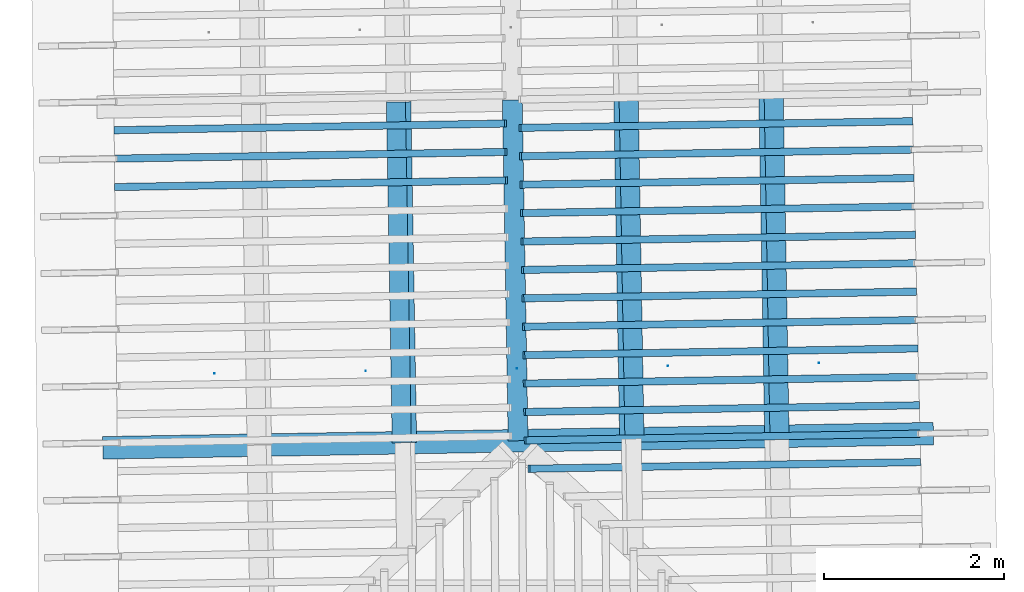
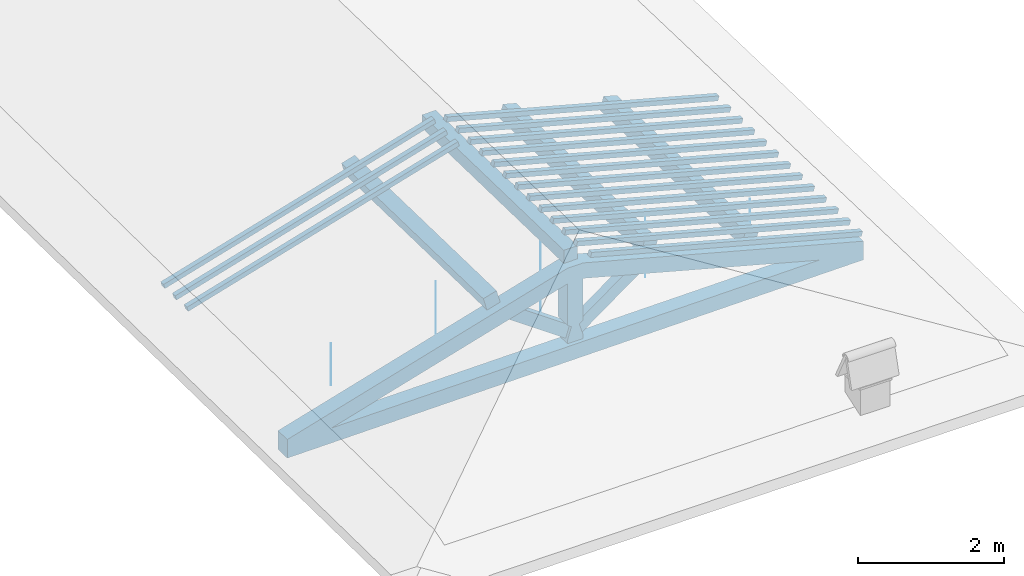
# One storey, part 3 of 19: 18 beams, 4 members, 2 elements without a shape of their own.
"""IFC4 building model written with IfcOpenShell, lengths in metres."""

from ifc_helpers import new_model, entity, si_unit, converted_unit, derived_unit, direction, frame, origin, place, context, subcontext, project, spatial, arc, indexed_curve, outline, extrude, source, transform, mapped, material, type_object, type_shapes, element, aggregate, save


model = new_model("IFC4")

# Units and contexts
model_context = context("Model", 3, precision=1e-05, world=origin(), true_north=direction((6.123233995736766e-17, 1.0)))
body_context = subcontext(model_context, "Body", "Model", "MODEL_VIEW")
ifc_project = project(units=[si_unit("LENGTHUNIT", "METRE"), si_unit("AREAUNIT", "SQUARE_METRE"), si_unit("VOLUMEUNIT", "CUBIC_METRE"), converted_unit("PLANEANGLEUNIT", "DEGREE", entity("IfcPlaneAngleMeasure", 0.017453292519943278), si_unit("PLANEANGLEUNIT", "RADIAN"), dimensions=[0, 0, 0, 0, 0, 0, 0]), derived_unit("THERMALTRANSMITTANCEUNIT", [(si_unit("MASSUNIT", "GRAM", prefix="KILO"), 1), (si_unit("THERMODYNAMICTEMPERATUREUNIT", "KELVIN"), -1), (si_unit("TIMEUNIT", "SECOND"), -3)])], contexts=[model_context])

# Site, building, storey
site_placement = place(None, origin())
site = spatial("IfcSite", under=ifc_project, at=site_placement, CompositionType="ELEMENT")
building_placement = place(site_placement, origin())
building = spatial("IfcBuilding", under=site, at=building_placement, CompositionType="ELEMENT")
storey_placement = place(building_placement, frame((0.0, 0.0, 3.28)))
storey = spatial("IfcBuildingStorey", under=building, at=storey_placement, Name="Livello Copertura", CompositionType="ELEMENT", Elevation=3.28)

# Beam
ifc_material_1 = material(Name="Telaio", Category="Legno")
beam_type_1 = type_object("IfcBeamType", Name="con e 18x18 2", PredefinedType="BEAM", material=ifc_material_1)
shared_shape_1 = source(origin(), body_context, "Body", "SweptSolid", [
    extrude(outline(indexed_curve([(-0.16541753369488893, -2.7162453774766275), (0.08463069471711139, -2.716245377476629), (0.16842467663126645, 1.5495047236372541), (-0.01356084740826559, 1.9493040088108127), (-0.07407699024522271, 1.933682022505188), (-0.16541753369488893, -2.7162453774766275)], self_intersect=False)), frame((-2.713680684761416, -0.12500000000000352, 0.5116016056385222), z_axis=(0.0, 1.0, 0.0), x_axis=(0.24995178089011919, 0.0, -0.9682582853917946)), (0.0, 0.0, 1.0), 0.24999999999999992),
    extrude(outline(indexed_curve([(-2.718970219470431, -0.11203953208496607), (1.9318542149690596, -0.11203953208496614), (1.9486617037575076, -0.05184187166013539), (1.5525136616356172, 0.137960467915034), (-2.7140593608917554, 0.137960467915034), (-2.718970219470431, -0.11203953208496607)], self_intersect=False)), frame((2.7136806847614197, -0.12500000000000352, 0.5116016056385372), z_axis=(0.0, 1.0, 0.0), x_axis=(0.9631625667976574, 0.0, -0.2689198206152686)), (0.0, 0.0, 1.0), 0.24999999999999992),
    extrude(outline(indexed_curve([(-0.5601835339455478, -0.12499999999999746), (-0.49768353394554415, -0.12499999999999749), (-0.2968792817361453, -0.062499999999998515), (-0.2526268150406443, -0.12499999999999746), (0.4434537562213674, -0.12499999999999747), (0.4609040697695109, -0.06249999999999742), (0.7030153386769692, -0.12499999999999746), (0.7030153386769719, 0.1249999999999892), (0.46090406976954656, 0.06249999999999748), (0.4434537562214021, 0.12499999999999911), (-0.2526268150406462, 0.12499999999999915), (-0.29687928173614625, 0.06250000000000018), (-0.4976835339455446, 0.12499999999999908), (-0.5601835339455477, 0.12499999999999911), (-0.5601835339455478, -0.12499999999999746)], self_intersect=False)), frame((0.0, -0.12500000000000397, 0.647683533945542), z_axis=(0.0, 1.0, 0.0), x_axis=(0.0, 0.0, 1.0)), (0.0, 0.0, 1.0), 0.24999999999999992),
    extrude(outline(indexed_curve([(-4.548711713227807, -0.7192326477239056), (-4.505299668811077, -0.9654345859769559), (4.563794928678348, 0.6336914821578127), (4.520382884261614, 0.8798934204108596), (4.107604035615938, 0.7296542061691604), (3.82531022235883, 0.7573333565645375), (-3.8536390513249863, -0.5966725838775957), (-4.109441637550861, -0.7192326477239057), (-4.548711713227807, -0.7192326477239056)], self_intersect=False)), frame((0.0, -0.12500000000000175, -0.0440696120362346), z_axis=(0.0, -1.0, 0.0), x_axis=(0.984807753012208, 0.0, -0.17364817766693108)), (0.0, 0.0, -1.0), 0.24999999999999986),
    extrude(outline(indexed_curve([(0.20359543107977635, -0.4090841915047363), (0.4613119776404389, -0.4090841915047362), (-0.27535475240621304, 0.4973840166014553), (-0.3895526563140025, 0.3207843664080172), (0.20359543107977635, -0.4090841915047363)], self_intersect=False)), frame((0.5239678106288662, -0.07500000000000369, 0.5550133154913391), z_axis=(0.0, 1.0, 0.0), x_axis=(0.9631625667976574, 0.0, -0.2689198206152682)), (0.0, 0.0, 1.0), 0.14999999999999994),
    extrude(outline(indexed_curve([(-0.4613119776404252, -0.4090841915047199), (-0.20359543107976297, -0.4090841915047199), (0.38955265631398844, 0.3207843664080003), (0.2753547524061997, 0.4973840166014395), (-0.4613119776404252, -0.4090841915047199)], self_intersect=False)), frame((-0.5239678106288467, -0.07500000000000369, 0.5550133154913305), z_axis=(0.0, 1.0, 0.0), x_axis=(0.9631625667976591, 0.0, 0.2689198206152626)), (0.0, 0.0, 1.0), 0.15),
])
type_shapes(beam_type_1, [shared_shape_1])
beam_1_placement = place(storey_placement, frame((-0.10915093127416141, 0.948347842470844, -0.33185813424974964), z_axis=(0.0, 0.0, 1.0), x_axis=(0.9998540424951864, 0.017084897015615302, 0.0)))
element("IfcBeam", 1, at=beam_1_placement, inside=storey, type_object=beam_type_1, material=ifc_material_1, Name="con e 18x18 2", ObjectType="con e 18x18 2", PredefinedType="BEAM", context=body_context, shape_type="MappedRepresentation", body=[
    mapped(shared_shape_1, transform((0.0, 0.0, 0.0), scale=1.0)),
])

# Members
ifc_material_2 = material(Name="Legno - Legno da costruzione", Category="Legno")
member_type_1 = type_object("IfcMemberType", Name="Legno:220x220", PredefinedType="PURLIN", material=ifc_material_2)
shared_shape_2 = source(origin(), body_context, "Body", "SweptSolid", [
    extrude(outline(indexed_curve([(-1.8889999897376843, -0.11000000000000167), (1.8889999897376841, -0.11000000000000167), (1.8889999897376843, 0.11000000000000167), (-1.8889999897376843, 0.11000000000000167), (-1.8889999897376843, -0.11000000000000167)], self_intersect=False)), frame((1.0262315609033124e-08, 0.0, -0.11000000000000543), z_axis=(0.0, 0.0, 1.0), x_axis=(-1.0, 0.0, 0.0)), (0.0, 0.0, 1.0), 0.21999999999999986),
])
type_shapes(member_type_1, [shared_shape_2])
member_1_placement = place(storey_placement, frame((-0.14155051099361587, 2.837069973977643, 1.1288407383727659), z_axis=(0.0, 0.0, 1.0), x_axis=(0.017084897015610563, -0.9998540424951864, 0.0)))
element("IfcMember", 2, at=member_1_placement, inside=storey, type_object=member_type_1, material=ifc_material_2, Name="Legno:220x220", ObjectType="Legno:220x220", PredefinedType="PURLIN", context=body_context, shape_type="MappedRepresentation", body=[
    mapped(shared_shape_2, transform((0.0, 0.0, 0.0), scale=1.0)),
])
member_type_2 = type_object("IfcMemberType", Name="Legno:220x220", PredefinedType="PURLIN", material=ifc_material_2)
shared_shape_3 = source(origin(), body_context, "Body", "SweptSolid", [
    extrude(outline(indexed_curve([(-0.11000000000000179, -0.10999999999999992), (0.1100000000000016, -0.11000000000000047), (0.11000000000000192, 0.10999999999999995), (-0.11000000000000132, 0.11), (-0.11000000000000179, -0.10999999999999992)], self_intersect=False)), frame((1.0867037662542156, 4.747207884589853, 4.096142666378187), z_axis=(0.01708489701561108, -0.9998540424951864, 0.0), x_axis=(-0.9630219859926791, -0.016455533263029863, 0.2689198206152636)), (0.0, 0.0, 1.0), 3.777999979475369),
])
type_shapes(member_type_2, [shared_shape_3])
member_2_placement = place(storey_placement, frame((0.0, 0.0, -3.28)))
element("IfcMember", 3, at=member_2_placement, inside=storey, type_object=member_type_2, material=ifc_material_2, Name="Legno:220x220", ObjectType="Legno:220x220", PredefinedType="PURLIN", context=body_context, shape_type="MappedRepresentation", body=[
    mapped(shared_shape_3, transform((0.0, 0.0, 0.0), scale=1.0)),
])
member_type_3 = type_object("IfcMemberType", Name="Legno:220x220", PredefinedType="PURLIN", material=ifc_material_2)
shared_shape_4 = source(origin(), body_context, "Body", "SweptSolid", [
    extrude(outline(indexed_curve([(-0.11000000000000161, -0.10999999999999995), (0.11000000000000143, -0.11000000000000047), (0.11000000000000161, 0.10999999999999995), (-0.11000000000000129, 0.10999999999999997), (-0.11000000000000161, -0.10999999999999995)], self_intersect=False)), frame((2.694765700683629, 4.774590186442459, 3.647098620102822), z_axis=(0.01708489701561113, -0.9998540424951865, 0.0), x_axis=(-0.963021985992679, -0.016455533263029905, 0.26891982061526426)), (0.0, 0.0, 1.0), 3.7779999794753683),
])
type_shapes(member_type_3, [shared_shape_4])
member_3_placement = place(storey_placement, frame((0.0, 0.0, -3.28)))
element("IfcMember", 4, at=member_3_placement, inside=storey, type_object=member_type_3, material=ifc_material_2, Name="Legno:220x220", ObjectType="Legno:220x220", PredefinedType="PURLIN", context=body_context, shape_type="MappedRepresentation", body=[
    mapped(shared_shape_4, transform((0.0, 0.0, 0.0), scale=1.0)),
])
member_type_4 = type_object("IfcMemberType", Name="Legno:220x220", PredefinedType="PURLIN", material=ifc_material_2)
shared_shape_5 = source(origin(), body_context, "Body", "SweptSolid", [
    extrude(outline(indexed_curve([(-0.11000000000000118, -0.11000000000000004), (0.11000000000000207, -0.10999999999999945), (0.11000000000000146, 0.10999999999999995), (-0.11000000000000193, 0.10999999999999997), (-0.11000000000000118, -0.11000000000000004)], self_intersect=False)), frame((-1.4340455079257437, 4.704385852621383, 4.096002252490915), z_axis=(0.017084897015611743, -0.9998540424951864, 0.0), x_axis=(-0.9630219859926791, -0.016455533263029863, -0.2689198206152636)), (0.0, 0.0, 1.0), 3.777999979475369),
])
type_shapes(member_type_4, [shared_shape_5])
member_4_placement = place(storey_placement, frame((0.0, 0.0, -3.28)))
element("IfcMember", 5, at=member_4_placement, inside=storey, type_object=member_type_4, material=ifc_material_2, Name="Legno:220x220", ObjectType="Legno:220x220", PredefinedType="PURLIN", context=body_context, shape_type="MappedRepresentation", body=[
    mapped(shared_shape_5, transform((0.0, 0.0, 0.0), scale=1.0)),
])

# Beam
ifc_material_3 = material(Name="Metallo - Acciaio - 345 MPa", Category="Metallo")
beam_type_2 = type_object("IfcBeamType", Name="Porta", PredefinedType="BEAM", material=ifc_material_3)
shared_shape_6 = source(origin(), body_context, "Body", "SweptSolid", [
    extrude(outline(indexed_curve([(-0.0025, 0.0), (-9.341026746681546e-18, -0.002499999999999973), (0.0025, 0.0), (1.5308084989342274e-19, 0.002499999999999973)], segments=[arc(1, 2, 3), arc(3, 4, 1)], self_intersect=False)), frame((3.3500000000000014, 0.0, 0.01799999999999821), z_axis=(0.0, 0.0, 1.0), x_axis=(0.0, -1.0, 0.0)), (0.0, 0.0, 1.0), 0.7000000000000034),
    extrude(outline(indexed_curve([(-0.0025, 0.0), (-9.341026746681546e-18, -0.002499999999999973), (0.0025, 0.0), (1.5308084989342274e-19, 0.002499999999999973)], segments=[arc(1, 2, 3), arc(3, 4, 1)], self_intersect=False)), frame((-3.350000000000001, 0.0, 0.01799999999999821), z_axis=(0.0, 0.0, 1.0), x_axis=(0.0, -1.0, 0.0)), (0.0, 0.0, 1.0), 0.7000000000000034),
    extrude(outline(indexed_curve([(-0.0025, 0.0), (-9.341026746681546e-18, -0.002499999999999973), (0.0025, 0.0), (1.5308084989342274e-19, 0.002499999999999973)], segments=[arc(1, 2, 3), arc(3, 4, 1)], self_intersect=False)), frame((1.6750000000000014, 0.0, 0.01799999999999821), z_axis=(0.0, 0.0, 1.0), x_axis=(0.0, -1.0, 0.0)), (0.0, 0.0, 1.0), 1.1350000000000036),
    extrude(outline(indexed_curve([(-0.0025, 0.0), (-9.341026746681546e-18, -0.002499999999999973), (0.0025, 0.0), (1.5308084989342274e-19, 0.002499999999999973)], segments=[arc(1, 2, 3), arc(3, 4, 1)], self_intersect=False)), frame((-1.6749999999999987, 0.0, 0.01799999999999821), z_axis=(0.0, 0.0, 1.0), x_axis=(0.0, -1.0, 0.0)), (0.0, 0.0, 1.0), 1.1350000000000036),
    extrude(outline(indexed_curve([(-0.0025, 4.038861436081489e-18), (-1.8222810943682823e-17, -0.0025000000000000044), (0.0025, -4.0388614360814286e-18), (3.483749923768857e-18, 0.0024999999999999957)], segments=[arc(1, 2, 3), arc(3, 4, 1)], self_intersect=False)), frame((0.0, 0.0, 0.017999999999998344), z_axis=(0.0, 0.0, 1.0), x_axis=(0.0, -1.0, 0.0)), (0.0, 0.0, 1.0), 1.350000000000003),
])
type_shapes(beam_type_2, [shared_shape_6])
beam_2_placement = place(storey_placement, frame((-0.12290406560098735, 1.750907887558534, -0.3492000000000056), z_axis=(0.0, 0.0, 1.0), x_axis=(0.9998547874088545, 0.017041246890830943, 0.0)))
element("IfcBeam", 6, at=beam_2_placement, inside=storey, type_object=beam_type_2, material=ifc_material_3, Name="Porta", ObjectType="Porta", PredefinedType="BEAM", context=body_context, shape_type="MappedRepresentation", body=[
    mapped(shared_shape_6, transform((0.0, 0.0, 0.0), scale=1.0)),
])

# Assembly, beams
assembly_1_placement = place(storey_placement, origin())
assembly_1 = element("IfcElementAssembly", 7, at=assembly_1_placement, inside=storey, Name="Sistema di travi strutturali:Sistema di travi strutturali", ObjectType="Sistema di travi strutturali:Sistema di travi strutturali", AssemblyPlace="NOTDEFINED", PredefinedType="BEAM_GRID")
beam_type_3 = type_object("IfcBeamType", Name="Legno:80x80", PredefinedType="JOIST", material=ifc_material_2)
shared_shape_7 = source(origin(), body_context, "Body", "SweptSolid", [
    extrude(outline(indexed_curve([(-2.247, -0.04000000000000169), (2.247, -0.04000000000000169), (2.247, 0.04000000000000169), (-2.247, 0.04000000000000169), (-2.247, -0.04000000000000169)], self_intersect=False)), frame((0.0, 0.0, -0.040000000000005476), z_axis=(0.0, 0.0, 1.0), x_axis=(-1.0, 0.0, 0.0)), (0.0, 0.0, 1.0), 0.07999999999999997),
])
type_shapes(beam_type_3, [shared_shape_7])
beam_3_placement = place(assembly_1_placement, frame((-2.412523717773911, 4.427895248678309, 0.6971087573780927), z_axis=(-0.26888056974925345, -0.004594467440668276, 0.9631625667976583), x_axis=(0.9630219859926786, 0.01645553326302695, 0.26891982061526537)))
beam_3 = element("IfcBeam", 8, at=beam_3_placement, type_object=beam_type_3, material=ifc_material_2, Name="Legno:80x80", ObjectType="Legno:80x80", PredefinedType="JOIST", context=body_context, shape_type="MappedRepresentation", body=[
    mapped(shared_shape_7, transform((0.0, 0.0, 0.0), scale=1.0)),
])
beam_type_4 = type_object("IfcBeamType", Name="Legno:80x80", PredefinedType="JOIST", material=ifc_material_2)
shared_shape_8 = source(origin(), body_context, "Body", "SweptSolid", [
    extrude(outline(indexed_curve([(-2.2485, -0.04000000000000169), (2.2485, -0.04000000000000169), (2.2485, 0.04000000000000169), (-2.2485, 0.04000000000000169), (-2.2485, -0.04000000000000169)], self_intersect=False)), frame((0.0, 0.0, -0.040000000000005476), z_axis=(0.0, 0.0, 1.0), x_axis=(-1.0, 0.0, 0.0)), (0.0, 0.0, 1.0), 0.07999999999999997),
])
type_shapes(beam_type_4, [shared_shape_8])
beam_4_placement = place(assembly_1_placement, frame((-2.4082892547392474, 4.1129216212784385, 0.6967883844181665), z_axis=(-0.26888056974925356, -0.0045944674406682776, 0.9631625667976583), x_axis=(0.9630219859926786, 0.01645553326302696, 0.2689198206152655)))
beam_4 = element("IfcBeam", 9, at=beam_4_placement, type_object=beam_type_4, material=ifc_material_2, Name="Legno:80x80", ObjectType="Legno:80x80", PredefinedType="JOIST", context=body_context, shape_type="MappedRepresentation", body=[
    mapped(shared_shape_8, transform((0.0, 0.0, 0.0), scale=1.0)),
])
beam_type_5 = type_object("IfcBeamType", Name="Legno:80x80", PredefinedType="JOIST", material=ifc_material_2)
shared_shape_9 = source(origin(), body_context, "Body", "SweptSolid", [
    extrude(outline(indexed_curve([(-2.2495, -0.04000000000000169), (2.2495, -0.04000000000000169), (2.2495, 0.04000000000000169), (-2.2495, 0.04000000000000169), (-2.2495, -0.04000000000000169)], self_intersect=False)), frame((0.0, 0.0, -0.040000000000005476), z_axis=(0.0, 0.0, 1.0), x_axis=(-1.0, 0.0, 0.0)), (0.0, 0.0, 1.0), 0.07999999999999997),
])
type_shapes(beam_type_5, [shared_shape_9])
beam_5_placement = place(assembly_1_placement, frame((-2.404054791704582, 3.797947993878563, 0.6964680114582396), z_axis=(-0.2688805697492535, -0.004594467440668276, 0.9631625667976583), x_axis=(0.9630219859926787, 0.016455533263026956, 0.2689198206152654)))
beam_5 = element("IfcBeam", 10, at=beam_5_placement, type_object=beam_type_5, material=ifc_material_2, Name="Legno:80x80", ObjectType="Legno:80x80", PredefinedType="JOIST", context=body_context, shape_type="MappedRepresentation", body=[
    mapped(shared_shape_9, transform((0.0, 0.0, 0.0), scale=1.0)),
])
aggregate(assembly_1, [beam_3, beam_4, beam_5])

assembly_2_placement = place(storey_placement, origin())
assembly_2 = element("IfcElementAssembly", 11, at=assembly_2_placement, inside=storey, Name="Sistema di travi strutturali:Sistema di travi strutturali", ObjectType="Sistema di travi strutturali:Sistema di travi strutturali", AssemblyPlace="NOTDEFINED", PredefinedType="BEAM_GRID")
beam_type_6 = type_object("IfcBeamType", Name="Legno:80x80", PredefinedType="JOIST", material=ifc_material_2)
shared_shape_10 = source(origin(), body_context, "Body", "SweptSolid", [
    extrude(outline(indexed_curve([(-2.2555, -0.04000000000000169), (2.2555, -0.04000000000000169), (2.2555, 0.04000000000000169), (-2.2555, 0.04000000000000169), (-2.2555, -0.04000000000000169)], self_intersect=False)), frame((0.0, 0.0, -0.040000000000005476), z_axis=(0.0, 0.0, 1.0), x_axis=(-1.0, 0.0, 0.0)), (0.0, 0.0, 1.0), 0.07999999999999997),
])
type_shapes(beam_type_6, [shared_shape_10])
beam_6_placement = place(assembly_2_placement, frame((2.082597457267619, 4.453794945756606, 0.6950774866976147), z_axis=(0.26888056974925345, 0.004594467440668277, 0.9631625667976583), x_axis=(-0.9630219859926786, -0.016455533263027795, 0.26891982061526537)))
beam_6 = element("IfcBeam", 12, at=beam_6_placement, type_object=beam_type_6, material=ifc_material_2, Name="Legno:80x80", ObjectType="Legno:80x80", PredefinedType="JOIST", context=body_context, shape_type="MappedRepresentation", body=[
    mapped(shared_shape_10, transform((0.0, 0.0, 0.0), scale=1.0)),
])
beam_type_7 = type_object("IfcBeamType", Name="Legno:80x80", PredefinedType="JOIST", material=ifc_material_2)
shared_shape_11 = source(origin(), body_context, "Body", "SweptSolid", [
    extrude(outline(indexed_curve([(-2.2565, -0.04000000000000169), (2.2565, -0.04000000000000169), (2.2565, 0.04000000000000169), (-2.2565, 0.04000000000000169), (-2.2565, -0.04000000000000169)], self_intersect=False)), frame((0.0, 0.0, -0.040000000000005476), z_axis=(0.0, 0.0, 1.0), x_axis=(-1.0, 0.0, 0.0)), (0.0, 0.0, 1.0), 0.07999999999999997),
])
type_shapes(beam_type_7, [shared_shape_11])
beam_7_placement = place(assembly_2_placement, frame((2.088990595047944, 4.138858204476255, 0.6947950588556767), z_axis=(0.26888056974925356, 0.004594467440668277, 0.9631625667976582), x_axis=(-0.9630219859926786, -0.016455533263027806, 0.2689198206152655)))
beam_7 = element("IfcBeam", 13, at=beam_7_placement, type_object=beam_type_7, material=ifc_material_2, Name="Legno:80x80", ObjectType="Legno:80x80", PredefinedType="JOIST", context=body_context, shape_type="MappedRepresentation", body=[
    mapped(shared_shape_11, transform((0.0, 0.0, 0.0), scale=1.0)),
])
beam_type_8 = type_object("IfcBeamType", Name="Legno:80x80", PredefinedType="JOIST", material=ifc_material_2)
shared_shape_12 = source(origin(), body_context, "Body", "SweptSolid", [
    extrude(outline(indexed_curve([(-2.2615, -0.04000000000000169), (2.2615, -0.04000000000000169), (2.2615, 0.04000000000000169), (-2.2615, 0.04000000000000169), (-2.2615, -0.04000000000000169)], self_intersect=False)), frame((0.0, 0.0, -0.040000000000005476), z_axis=(0.0, 0.0, 1.0), x_axis=(-1.0, 0.0, 0.0)), (0.0, 0.0, 1.0), 0.07999999999999997),
])
type_shapes(beam_type_8, [shared_shape_12])
beam_8_placement = place(assembly_2_placement, frame((2.1209562839495626, 2.564174498074516, 0.6933829196459858), z_axis=(0.26888056974925345, 0.004594467440668276, 0.9631625667976583), x_axis=(-0.9630219859926786, -0.016455533263027823, 0.26891982061526537)))
beam_8 = element("IfcBeam", 14, at=beam_8_placement, type_object=beam_type_8, material=ifc_material_2, Name="Legno:80x80", ObjectType="Legno:80x80", PredefinedType="JOIST", context=body_context, shape_type="MappedRepresentation", body=[
    mapped(shared_shape_12, transform((0.0, 0.0, 0.0), scale=1.0)),
])
beam_type_9 = type_object("IfcBeamType", Name="Legno:80x80", PredefinedType="JOIST", material=ifc_material_2)
shared_shape_13 = source(origin(), body_context, "Body", "SweptSolid", [
    extrude(outline(indexed_curve([(-2.249, -0.04000000000000169), (2.249, -0.04000000000000169), (2.249, 0.04000000000000169), (-2.249, 0.04000000000000169), (-2.249, -0.04000000000000169)], self_intersect=False)), frame((0.0, 0.0, -0.040000000000005476), z_axis=(0.0, 0.0, 1.0), x_axis=(-1.0, 0.0, 0.0)), (0.0, 0.0, 1.0), 0.07999999999999997),
])
type_shapes(beam_type_9, [shared_shape_13])
beam_9_placement = place(assembly_2_placement, frame((2.177684516118423, 0.6748679356073123, 0.6865587737267891), z_axis=(0.26888056974925334, 0.004594467440668274, 0.9631625667976583), x_axis=(-0.9630219859926787, -0.016455533263027886, 0.26891982061526526)))
beam_9 = element("IfcBeam", 15, at=beam_9_placement, type_object=beam_type_9, material=ifc_material_2, Name="Legno:80x80", ObjectType="Legno:80x80", PredefinedType="JOIST", context=body_context, shape_type="MappedRepresentation", body=[
    mapped(shared_shape_13, transform((0.0, 0.0, 0.0), scale=1.0)),
])
beam_type_10 = type_object("IfcBeamType", Name="Legno:80x80", PredefinedType="JOIST", material=ifc_material_2)
shared_shape_14 = source(origin(), body_context, "Body", "SweptSolid", [
    extrude(outline(indexed_curve([(-2.267, -0.04000000000000169), (2.267, -0.04000000000000169), (2.267, 0.04000000000000169), (-2.267, 0.04000000000000169), (-2.267, -0.04000000000000169)], self_intersect=False)), frame((0.0, 0.0, -0.040000000000005476), z_axis=(0.0, 0.0, 1.0), x_axis=(-1.0, 0.0, 0.0)), (0.0, 0.0, 1.0), 0.07999999999999997),
])
type_shapes(beam_type_10, [shared_shape_14])
beam_10_placement = place(assembly_2_placement, frame((2.15292197285118, 0.9894907916727746, 0.6919707804362961), z_axis=(0.2688805697492535, 0.004594467440668278, 0.9631625667976583), x_axis=(-0.9630219859926786, -0.016455533263027868, 0.2689198206152654)))
beam_10 = element("IfcBeam", 16, at=beam_10_placement, type_object=beam_type_10, material=ifc_material_2, Name="Legno:80x80", ObjectType="Legno:80x80", PredefinedType="JOIST", context=body_context, shape_type="MappedRepresentation", body=[
    mapped(shared_shape_14, transform((0.0, 0.0, 0.0), scale=1.0)),
])
beam_type_11 = type_object("IfcBeamType", Name="Legno:80x80", PredefinedType="JOIST", material=ifc_material_2)
shared_shape_15 = source(origin(), body_context, "Body", "SweptSolid", [
    extrude(outline(indexed_curve([(-2.266, -0.04000000000000169), (2.266, -0.04000000000000169), (2.266, 0.04000000000000169), (-2.266, 0.04000000000000169), (-2.266, -0.04000000000000169)], self_intersect=False)), frame((0.0, 0.0, -0.040000000000005476), z_axis=(0.0, 0.0, 1.0), x_axis=(-1.0, 0.0, 0.0)), (0.0, 0.0, 1.0), 0.07999999999999997),
])
type_shapes(beam_type_11, [shared_shape_15])
beam_11_placement = place(assembly_2_placement, frame((2.1465288350708565, 1.304427532953123, 0.6922532082782331), z_axis=(0.2688805697492534, 0.004594467440668276, 0.9631625667976583), x_axis=(-0.9630219859926786, -0.016455533263027892, 0.2689198206152653)))
beam_11 = element("IfcBeam", 17, at=beam_11_placement, type_object=beam_type_11, material=ifc_material_2, Name="Legno:80x80", ObjectType="Legno:80x80", PredefinedType="JOIST", context=body_context, shape_type="MappedRepresentation", body=[
    mapped(shared_shape_15, transform((0.0, 0.0, 0.0), scale=1.0)),
])
beam_type_12 = type_object("IfcBeamType", Name="Legno:80x80", PredefinedType="JOIST", material=ifc_material_2)
shared_shape_16 = source(origin(), body_context, "Body", "SweptSolid", [
    extrude(outline(indexed_curve([(-2.265, -0.04000000000000169), (2.265, -0.04000000000000169), (2.265, 0.04000000000000169), (-2.265, 0.04000000000000169), (-2.265, -0.04000000000000169)], self_intersect=False)), frame((0.0, 0.0, -0.040000000000005476), z_axis=(0.0, 0.0, 1.0), x_axis=(-1.0, 0.0, 0.0)), (0.0, 0.0, 1.0), 0.07999999999999997),
])
type_shapes(beam_type_12, [shared_shape_16])
beam_12_placement = place(assembly_2_placement, frame((2.1401356972905323, 1.6193642742334715, 0.6925356361201712), z_axis=(0.26888056974925345, 0.004594467440668275, 0.9631625667976583), x_axis=(-0.9630219859926786, -0.016455533263027886, 0.26891982061526537)))
beam_12 = element("IfcBeam", 18, at=beam_12_placement, type_object=beam_type_12, material=ifc_material_2, Name="Legno:80x80", ObjectType="Legno:80x80", PredefinedType="JOIST", context=body_context, shape_type="MappedRepresentation", body=[
    mapped(shared_shape_16, transform((0.0, 0.0, 0.0), scale=1.0)),
])
beam_type_13 = type_object("IfcBeamType", Name="Legno:80x80", PredefinedType="JOIST", material=ifc_material_2)
shared_shape_17 = source(origin(), body_context, "Body", "SweptSolid", [
    extrude(outline(indexed_curve([(-2.2635, -0.04000000000000169), (2.2635, -0.04000000000000169), (2.2635, 0.04000000000000169), (-2.2635, 0.04000000000000169), (-2.2635, -0.04000000000000169)], self_intersect=False)), frame((0.0, 0.0, -0.040000000000005476), z_axis=(0.0, 0.0, 1.0), x_axis=(-1.0, 0.0, 0.0)), (0.0, 0.0, 1.0), 0.07999999999999997),
])
type_shapes(beam_type_13, [shared_shape_17])
beam_13_placement = place(assembly_2_placement, frame((2.133742559510209, 1.9343010155138194, 0.69281806396211), z_axis=(0.2688805697492534, 0.004594467440668275, 0.9631625667976583), x_axis=(-0.9630219859926787, -0.016455533263027886, 0.2689198206152653)))
beam_13 = element("IfcBeam", 19, at=beam_13_placement, type_object=beam_type_13, material=ifc_material_2, Name="Legno:80x80", ObjectType="Legno:80x80", PredefinedType="JOIST", context=body_context, shape_type="MappedRepresentation", body=[
    mapped(shared_shape_17, transform((0.0, 0.0, 0.0), scale=1.0)),
])
beam_type_14 = type_object("IfcBeamType", Name="Legno:80x80", PredefinedType="JOIST", material=ifc_material_2)
shared_shape_18 = source(origin(), body_context, "Body", "SweptSolid", [
    extrude(outline(indexed_curve([(-2.2625, -0.04000000000000169), (2.2625, -0.04000000000000169), (2.2625, 0.04000000000000169), (-2.2625, 0.04000000000000169), (-2.2625, -0.04000000000000169)], self_intersect=False)), frame((0.0, 0.0, -0.040000000000005476), z_axis=(0.0, 0.0, 1.0), x_axis=(-1.0, 0.0, 0.0)), (0.0, 0.0, 1.0), 0.07999999999999997),
])
type_shapes(beam_type_14, [shared_shape_18])
beam_14_placement = place(assembly_2_placement, frame((2.1273494217298854, 2.2492377567941673, 0.693100491804048), z_axis=(0.2688805697492534, 0.004594467440668275, 0.9631625667976583), x_axis=(-0.9630219859926786, -0.01645553326302788, 0.2689198206152653)))
beam_14 = element("IfcBeam", 20, at=beam_14_placement, type_object=beam_type_14, material=ifc_material_2, Name="Legno:80x80", ObjectType="Legno:80x80", PredefinedType="JOIST", context=body_context, shape_type="MappedRepresentation", body=[
    mapped(shared_shape_18, transform((0.0, 0.0, 0.0), scale=1.0)),
])
beam_type_15 = type_object("IfcBeamType", Name="Legno:80x80", PredefinedType="JOIST", material=ifc_material_2)
shared_shape_19 = source(origin(), body_context, "Body", "SweptSolid", [
    extrude(outline(indexed_curve([(-2.2605, -0.04000000000000169), (2.2605, -0.04000000000000169), (2.2605, 0.04000000000000169), (-2.2605, 0.04000000000000169), (-2.2605, -0.04000000000000169)], self_intersect=False)), frame((0.0, 0.0, -0.040000000000005476), z_axis=(0.0, 0.0, 1.0), x_axis=(-1.0, 0.0, 0.0)), (0.0, 0.0, 1.0), 0.07999999999999997),
])
type_shapes(beam_type_15, [shared_shape_19])
beam_15_placement = place(assembly_2_placement, frame((2.114563146169238, 2.879111239354864, 0.6936653474879233), z_axis=(0.26888056974925345, 0.004594467440668276, 0.9631625667976583), x_axis=(-0.9630219859926786, -0.01645553326302782, 0.26891982061526537)))
beam_15 = element("IfcBeam", 21, at=beam_15_placement, type_object=beam_type_15, material=ifc_material_2, Name="Legno:80x80", ObjectType="Legno:80x80", PredefinedType="JOIST", context=body_context, shape_type="MappedRepresentation", body=[
    mapped(shared_shape_19, transform((0.0, 0.0, 0.0), scale=1.0)),
])
beam_type_16 = type_object("IfcBeamType", Name="Legno:80x80", PredefinedType="JOIST", material=ifc_material_2)
shared_shape_20 = source(origin(), body_context, "Body", "SweptSolid", [
    extrude(outline(indexed_curve([(-2.2595, -0.04000000000000169), (2.2595, -0.04000000000000169), (2.2595, 0.04000000000000169), (-2.2595, 0.04000000000000169), (-2.2595, -0.04000000000000169)], self_intersect=False)), frame((0.0, 0.0, -0.040000000000005476), z_axis=(0.0, 0.0, 1.0), x_axis=(-1.0, 0.0, 0.0)), (0.0, 0.0, 1.0), 0.07999999999999997),
])
type_shapes(beam_type_16, [shared_shape_20])
beam_16_placement = place(assembly_2_placement, frame((2.1081700083889143, 3.1940479806352116, 0.6939477753298616), z_axis=(0.2688805697492534, 0.004594467440668275, 0.9631625667976583), x_axis=(-0.9630219859926786, -0.016455533263027816, 0.2689198206152653)))
beam_16 = element("IfcBeam", 22, at=beam_16_placement, type_object=beam_type_16, material=ifc_material_2, Name="Legno:80x80", ObjectType="Legno:80x80", PredefinedType="JOIST", context=body_context, shape_type="MappedRepresentation", body=[
    mapped(shared_shape_20, transform((0.0, 0.0, 0.0), scale=1.0)),
])
beam_type_17 = type_object("IfcBeamType", Name="Legno:80x80", PredefinedType="JOIST", material=ifc_material_2)
shared_shape_21 = source(origin(), body_context, "Body", "SweptSolid", [
    extrude(outline(indexed_curve([(-2.2585, -0.04000000000000169), (2.2585, -0.04000000000000169), (2.2585, 0.04000000000000169), (-2.2585, 0.04000000000000169), (-2.2585, -0.04000000000000169)], self_intersect=False)), frame((0.0, 0.0, -0.040000000000005476), z_axis=(0.0, 0.0, 1.0), x_axis=(-1.0, 0.0, 0.0)), (0.0, 0.0, 1.0), 0.07999999999999997),
])
type_shapes(beam_type_17, [shared_shape_21])
beam_17_placement = place(assembly_2_placement, frame((2.1017768706085906, 3.508984721915559, 0.6942302031717996), z_axis=(0.2688805697492535, 0.004594467440668277, 0.9631625667976583), x_axis=(-0.9630219859926786, -0.016455533263027813, 0.2689198206152654)))
beam_17 = element("IfcBeam", 23, at=beam_17_placement, type_object=beam_type_17, material=ifc_material_2, Name="Legno:80x80", ObjectType="Legno:80x80", PredefinedType="JOIST", context=body_context, shape_type="MappedRepresentation", body=[
    mapped(shared_shape_21, transform((0.0, 0.0, 0.0), scale=1.0)),
])
beam_type_18 = type_object("IfcBeamType", Name="Legno:80x80", PredefinedType="JOIST", material=ifc_material_2)
shared_shape_22 = source(origin(), body_context, "Body", "SweptSolid", [
    extrude(outline(indexed_curve([(-2.2575000000000003, -0.04000000000000169), (2.2575000000000003, -0.04000000000000169), (2.2575000000000003, 0.04000000000000169), (-2.2575000000000003, 0.04000000000000169), (-2.2575000000000003, -0.04000000000000169)], self_intersect=False)), frame((0.0, 0.0, -0.040000000000005476), z_axis=(0.0, 0.0, 1.0), x_axis=(-1.0, 0.0, 0.0)), (0.0, 0.0, 1.0), 0.07999999999999997),
])
type_shapes(beam_type_18, [shared_shape_22])
beam_18_placement = place(assembly_2_placement, frame((2.095383732828268, 3.8239214631959086, 0.6945126310137372), z_axis=(0.26888056974925345, 0.004594467440668275, 0.9631625667976583), x_axis=(-0.9630219859926787, -0.016455533263027806, 0.26891982061526537)))
beam_18 = element("IfcBeam", 24, at=beam_18_placement, type_object=beam_type_18, material=ifc_material_2, Name="Legno:80x80", ObjectType="Legno:80x80", PredefinedType="JOIST", context=body_context, shape_type="MappedRepresentation", body=[
    mapped(shared_shape_22, transform((0.0, 0.0, 0.0), scale=1.0)),
])
aggregate(assembly_2, [beam_9, beam_10, beam_11, beam_12, beam_13, beam_14, beam_8, beam_15, beam_16, beam_17, beam_18, beam_7, beam_6])

save(model, "model.ifc")
